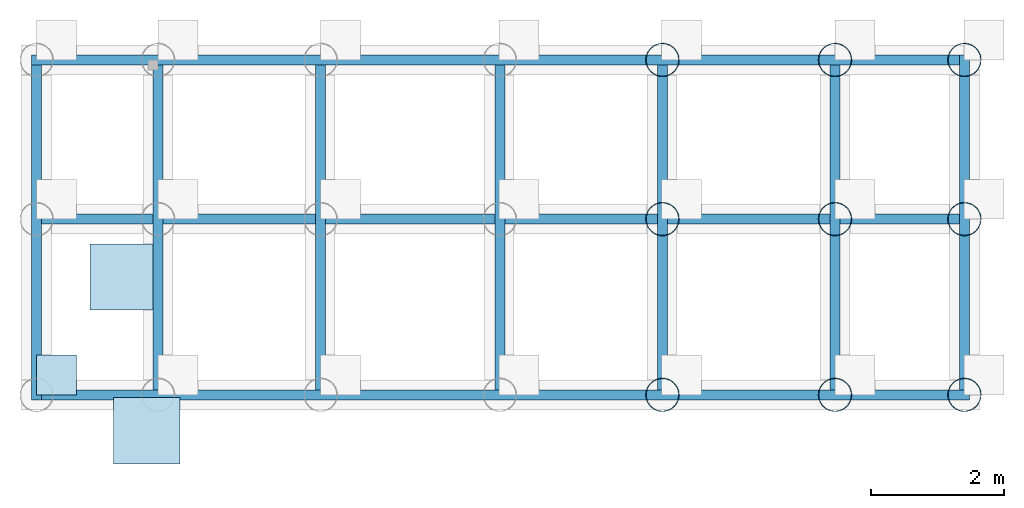
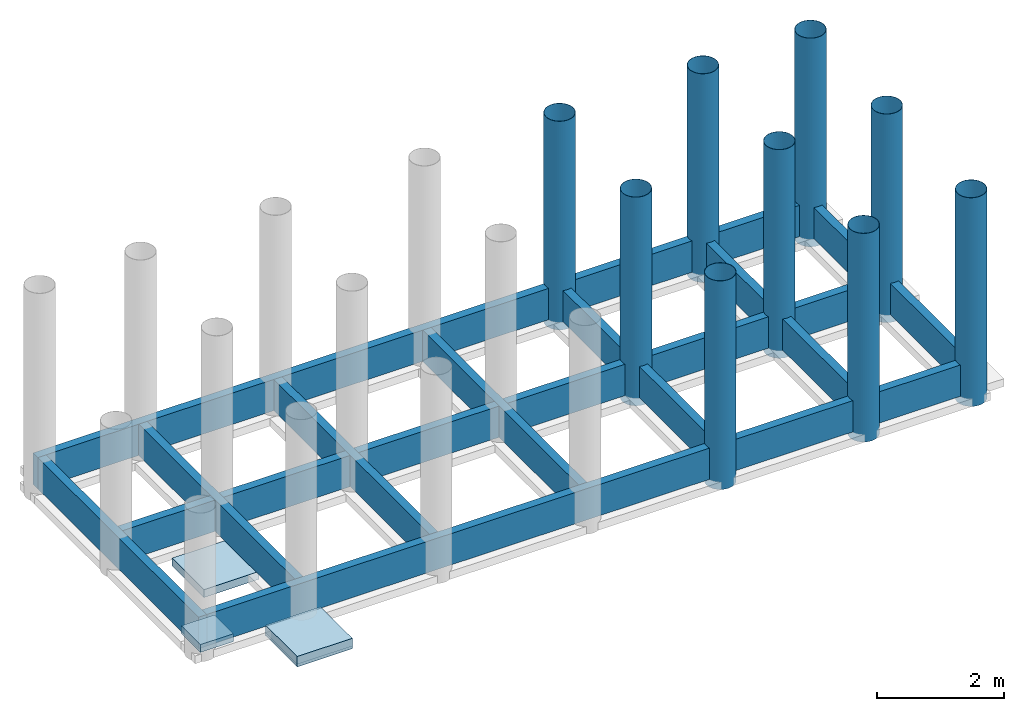
# One storey, part 2 of 2: 10 walls, 9 columns, 7 slabs.
"""IFC4 building model written with IfcOpenShell, lengths in millimetres."""

from ifc_helpers import new_model, entity, si_unit, converted_unit, frame, origin_with_axes, origin_2d_with_axis, place, context, subcontext, project, spatial, line, indexed_curve, rectangle, hollow_circle, outline, extrude, material, layer, layer_set, layer_usage, material_profile, profile_set, profile_usage, type_object, element, save


model = new_model("IFC4")

# Units and contexts
model_context = context("Model", 3, precision=1e-05, world=origin_with_axes())
plan_context = context("Plan", 2, precision=1e-05, world=origin_2d_with_axis())
body_context = subcontext(model_context, "Body", "Model", "MODEL_VIEW")
ifc_project = project(units=[si_unit("AREAUNIT", "SQUARE_METRE"), si_unit("VOLUMEUNIT", "CUBIC_METRE"), si_unit("LENGTHUNIT", "METRE", prefix="MILLI"), converted_unit("PLANEANGLEUNIT", "degree", entity("IfcReal", 0.0174532925199433), si_unit("PLANEANGLEUNIT", "RADIAN"), dimensions=[0, 0, 0, 0, 0, 0, 0])], contexts=[model_context, plan_context])

# Site, building, storey
site_placement = place(None, frame((-860.053181648254, 6515.22541046143, 2.98023223876953e-05), z_axis=(0.0, 0.0, 1.0), x_axis=(7.54979012640431e-08, -0.999999999999997, 0.0)))
site = spatial("IfcSite", under=ifc_project, at=site_placement)
building_placement = place(site_placement, frame((0.0, 0.0, 0.0), z_axis=(0.0, 0.0, 1.0), x_axis=(1.0, -1.32348898008484e-23, 0.0)))
building = spatial("IfcBuilding", under=site, at=building_placement, Name="Building")
storey_placement = place(building_placement, frame((0.222206115722656, -1.67760250135984e-08, -750.000089406967), z_axis=(0.0, 0.0, 1.0), x_axis=(7.54979012640431e-08, 0.999999999999997, 0.0)))
storey = spatial("IfcBuildingStorey", under=building, at=storey_placement, Name="FOUNDATION")

# Columns
ifc_material_1 = material(Name="Mass Concrete", Category="Concrete")
ifc_material_profile = material_profile(ifc_material_1, rectangle(XDim=150.0, YDim=150.0), Name="Square Column", Category="Structure", Priority=1)
ifc_profile_set = profile_set([ifc_material_profile], Name="RC_COL_150x150")
ifc_profile_usage_1 = profile_usage(ifc_profile_set, cardinal=5)
column_type = type_object("IfcColumnType", Name="C1", PredefinedType="NOTDEFINED", material=ifc_profile_set)
column_1_placement = place(storey_placement, frame((9554.95464801788, -626.263618469242, -149.999976158142), z_axis=(0.0, 0.0, 1.0), x_axis=(1.0, 1.32348898008484e-23, 0.0)))
element("IfcColumn", 1, at=column_1_placement, inside=storey, type_object=column_type, material=ifc_profile_usage_1, Name="C1", context=body_context, shape_type="SweptSolid", body=[
    extrude(hollow_circle(Radius=250.0, WallThickness=5.0), origin_with_axes(), (0.0, 0.0, 1.0), 4000.0),
])
ifc_profile_usage_2 = profile_usage(ifc_profile_set, cardinal=5)
column_2_placement = place(storey_placement, frame((12155.0036668777, -626.263618469242, -149.999976158142), z_axis=(0.0, 0.0, 1.0), x_axis=(1.0, 1.32348898008484e-23, 0.0)))
element("IfcColumn", 2, at=column_2_placement, inside=storey, type_object=column_type, material=ifc_profile_usage_2, Name="C1", context=body_context, shape_type="SweptSolid", body=[
    extrude(hollow_circle(Radius=250.0, WallThickness=5.0), origin_with_axes(), (0.0, 0.0, 1.0), 4000.0),
])
ifc_profile_usage_3 = profile_usage(ifc_profile_set, cardinal=5)
column_3_placement = place(storey_placement, frame((14105.0034761429, -626.263618469242, -149.999976158142), z_axis=(0.0, 0.0, 1.0), x_axis=(1.0, 1.32348898008484e-23, 0.0)))
element("IfcColumn", 3, at=column_3_placement, inside=storey, type_object=column_type, material=ifc_profile_usage_3, Name="C1", context=body_context, shape_type="SweptSolid", body=[
    extrude(hollow_circle(Radius=250.0, WallThickness=5.0), origin_with_axes(), (0.0, 0.0, 1.0), 4000.0),
])
ifc_profile_usage_4 = profile_usage(ifc_profile_set, cardinal=5)
column_4_placement = place(storey_placement, frame((14105.0034761429, -3024.68276023865, -149.999976158142), z_axis=(0.0, 0.0, 1.0), x_axis=(1.0, 1.32348898008484e-23, 0.0)))
element("IfcColumn", 4, at=column_4_placement, inside=storey, type_object=column_type, material=ifc_profile_usage_4, Name="C1", context=body_context, shape_type="SweptSolid", body=[
    extrude(hollow_circle(Radius=250.0, WallThickness=5.0), origin_with_axes(), (0.0, 0.0, 1.0), 4000.0),
])
ifc_profile_usage_5 = profile_usage(ifc_profile_set, cardinal=5)
column_5_placement = place(storey_placement, frame((14105.0034761429, -5672.84035682678, -149.999976158142), z_axis=(0.0, 0.0, 1.0), x_axis=(1.0, 1.32348898008484e-23, 0.0)))
element("IfcColumn", 5, at=column_5_placement, inside=storey, type_object=column_type, material=ifc_profile_usage_5, Name="C1", context=body_context, shape_type="SweptSolid", body=[
    extrude(hollow_circle(Radius=250.0, WallThickness=5.0), origin_with_axes(), (0.0, 0.0, 1.0), 4000.0),
])
ifc_profile_usage_6 = profile_usage(ifc_profile_set, cardinal=5)
column_6_placement = place(storey_placement, frame((12155.0046205521, -5672.84035682678, -149.999976158142), z_axis=(0.0, 0.0, 1.0), x_axis=(1.0, 1.32348898008484e-23, 0.0)))
element("IfcColumn", 6, at=column_6_placement, inside=storey, type_object=column_type, material=ifc_profile_usage_6, Name="C1", context=body_context, shape_type="SweptSolid", body=[
    extrude(hollow_circle(Radius=250.0, WallThickness=5.0), origin_with_axes(), (0.0, 0.0, 1.0), 4000.0),
])
ifc_profile_usage_7 = profile_usage(ifc_profile_set, cardinal=5)
column_7_placement = place(storey_placement, frame((9555.04906177521, -5672.84035682678, -149.999976158142), z_axis=(0.0, 0.0, 1.0), x_axis=(1.0, 1.32348898008484e-23, 0.0)))
element("IfcColumn", 7, at=column_7_placement, inside=storey, type_object=column_type, material=ifc_profile_usage_7, Name="C1", context=body_context, shape_type="SweptSolid", body=[
    extrude(hollow_circle(Radius=250.0, WallThickness=5.0), origin_with_axes(), (0.0, 0.0, 1.0), 4000.0),
])
ifc_profile_usage_8 = profile_usage(ifc_profile_set, cardinal=5)
column_8_placement = place(storey_placement, frame((9555.00137805939, -3024.67823028565, -149.999976158142), z_axis=(0.0, 0.0, 1.0), x_axis=(1.0, 1.32348898008484e-23, 0.0)))
element("IfcColumn", 8, at=column_8_placement, inside=storey, type_object=column_type, material=ifc_profile_usage_8, Name="C1", context=body_context, shape_type="SweptSolid", body=[
    extrude(hollow_circle(Radius=250.0, WallThickness=5.0), origin_with_axes(), (0.0, 0.0, 1.0), 4000.0),
])
ifc_profile_usage_9 = profile_usage(ifc_profile_set, cardinal=5)
column_9_placement = place(storey_placement, frame((12155.0036668777, -3024.67823028565, -149.999976158142), z_axis=(0.0, 0.0, 1.0), x_axis=(1.0, 1.32348898008484e-23, 0.0)))
element("IfcColumn", 9, at=column_9_placement, inside=storey, type_object=column_type, material=ifc_profile_usage_9, Name="C1", context=body_context, shape_type="SweptSolid", body=[
    extrude(hollow_circle(Radius=250.0, WallThickness=5.0), origin_with_axes(), (0.0, 0.0, 1.0), 4000.0),
])

# Slabs
ifc_layer_1 = layer(ifc_material_1, 150.0, Name="Foundation Footing Layer", Category="Substrate", Priority=1)
ifc_layer_set_1 = layer_set([ifc_layer_1])
ifc_layer_usage_1 = layer_usage(ifc_layer_set_1, "AXIS3", "POSITIVE", 0.0)
slab_type_1 = type_object("IfcSlabType", Name="FLR150", PredefinedType="NOTDEFINED", material=ifc_layer_set_1)
slab_1_placement = place(storey_placement, frame((929.933577775955, -4396.21543884278, -149.999976158142), z_axis=(0.0, 0.0, 1.0), x_axis=(1.0, 1.32348898008484e-23, 0.0)))
element("IfcSlab", 10, at=slab_1_placement, inside=storey, type_object=slab_type_1, material=ifc_layer_usage_1, Name="FLR150", context=body_context, shape_type="SweptSolid", body=[
    extrude(outline(indexed_curve([(0.0, 0.0), (1000.0, 0.0), (1000.0, 1000.0), (0.0, 1000.0), (0.0, 0.0)])), None, (0.0, 0.0, 1.0), 150.0),
])
ifc_layer_usage_2 = layer_usage(ifc_layer_set_1, "AXIS3", "POSITIVE", 0.0)
slab_2_placement = place(storey_placement, frame((1281.97777271271, -6713.08445930481, -149.999976158142), z_axis=(0.0, 0.0, 1.0), x_axis=(1.0, 1.32348898008484e-23, 0.0)))
element("IfcSlab", 11, at=slab_2_placement, inside=storey, type_object=slab_type_1, material=ifc_layer_usage_2, Name="FLR150", context=body_context, shape_type="SweptSolid", body=[
    extrude(outline(indexed_curve([(0.0, 0.0), (1000.0, 0.0), (1000.0, 1000.0), (0.0, 1000.0), (0.0, 0.0)])), None, (0.0, 0.0, 1.0), 150.0),
])
ifc_layer_2 = layer(ifc_material_1, 150.0, Name="Concrete Footing Layer", Category="Structure", Priority=1)
ifc_material_2 = material(Name="Light Concrete", Category="Concrete")
ifc_layer_3 = layer(ifc_material_2, 50.0, Name="Blinding Layer", Category="Substrate", Priority=2)
ifc_layer_set_2 = layer_set([ifc_layer_2, ifc_layer_3], Name="FTG_COL_2LYR")
ifc_layer_usage_3 = layer_usage(ifc_layer_set_2, "AXIS3", "POSITIVE", 0.0)
slab_type_2 = type_object("IfcSlabType", Name="FLR_150", PredefinedType="NOTDEFINED", material=ifc_layer_set_2)
slab_3_placement = place(storey_placement, frame((1281.97777271271, -6713.08445930481, -199.999988079071), z_axis=(0.0, 0.0, 1.0), x_axis=(1.0, 1.32348898008484e-23, 0.0)))
element("IfcSlab", 12, at=slab_3_placement, inside=storey, type_object=slab_type_2, material=ifc_layer_usage_3, Name="FLR_150", context=body_context, shape_type="SweptSolid", body=[
    extrude(outline(indexed_curve([(0.0, 0.0), (1000.0, 0.0), (1000.0, 1000.0), (0.0, 1000.0), (0.0, 0.0)])), None, (0.0, 0.0, 1.0), 200.0),
])
ifc_layer_usage_4 = layer_usage(ifc_layer_set_2, "AXIS3", "POSITIVE", 0.0)
slab_4_placement = place(storey_placement, frame((1281.97777271271, -6713.08445930481, -199.999988079071), z_axis=(0.0, 0.0, 1.0), x_axis=(1.0, 1.32348898008484e-23, 0.0)))
element("IfcSlab", 13, at=slab_4_placement, inside=storey, type_object=slab_type_2, material=ifc_layer_usage_4, Name="FLR_150", context=body_context, shape_type="SweptSolid", body=[
    extrude(outline(indexed_curve([(0.0, 0.0), (1000.0, 0.0), (1000.0, 1000.0), (0.0, 1000.0), (0.0, 0.0)])), None, (0.0, 0.0, 1.0), 200.0),
])
ifc_layer_4 = layer(ifc_material_1, 150.0, Name="Column Footing Layer", Category="Structure", Priority=1)
ifc_layer_set_3 = layer_set([ifc_layer_4], Name="FTG_COL_1LYR")
ifc_layer_usage_5 = layer_usage(ifc_layer_set_3, "AXIS3", "POSITIVE", 0.0)
slab_type_3 = type_object("IfcSlabType", Name="FLR_150", PredefinedType="NOTDEFINED", material=ifc_layer_set_3)
slab_5_placement = place(storey_placement, frame((124.994397163391, -5674.44968223572, -147.661149501801), z_axis=(0.0, 0.0, 1.0), x_axis=(1.0, 1.32348898008484e-23, 0.0)))
element("IfcSlab", 14, at=slab_5_placement, inside=storey, type_object=slab_type_3, material=ifc_layer_usage_5, Name="FLR250", context=body_context, shape_type="SweptSolid", body=[
    extrude(outline(indexed_curve([(0.0, 0.0), (600.000023841858, 0.0), (600.000023841858, 600.000023841858), (0.0, 600.000023841858)], segments=[line(3, 2), line(2, 1), line(1, 4), line(4, 3)], self_intersect=False)), None, (0.0, 0.0, 1.0), 150.0),
])
ifc_layer_usage_6 = layer_usage(ifc_layer_set_3, "AXIS3", "POSITIVE", 0.0)
slab_6_placement = place(storey_placement, frame((124.994397163391, -5674.44968223572, -147.661149501801), z_axis=(0.0, 0.0, 1.0), x_axis=(1.0, 1.32348898008484e-23, 0.0)))
element("IfcSlab", 15, at=slab_6_placement, inside=storey, type_object=slab_type_3, material=ifc_layer_usage_6, Name="FLR250", context=body_context, shape_type="SweptSolid", body=[
    extrude(outline(indexed_curve([(0.0, 0.0), (600.000023841858, 0.0), (600.000023841858, 600.000023841858), (0.0, 600.000023841858)], segments=[line(3, 2), line(2, 1), line(1, 4), line(4, 3)], self_intersect=False)), None, (0.0, 0.0, 1.0), 150.0),
])
ifc_layer_usage_7 = layer_usage(ifc_layer_set_3, "AXIS3", "POSITIVE", 0.0)
slab_7_placement = place(storey_placement, frame((124.994397163391, -5674.44968223572, -147.661149501801), z_axis=(0.0, 0.0, 1.0), x_axis=(1.0, 1.32348898008484e-23, 0.0)))
element("IfcSlab", 16, at=slab_7_placement, inside=storey, type_object=slab_type_3, material=ifc_layer_usage_7, Name="FLR250", context=body_context, shape_type="SweptSolid", body=[
    extrude(outline(indexed_curve([(0.0, 0.0), (600.000023841858, 0.0), (600.000023841858, 600.000023841858), (0.0, 600.000023841858)], segments=[line(3, 2), line(2, 1), line(1, 4), line(4, 3)], self_intersect=False)), None, (0.0, 0.0, 1.0), 150.0),
])

# Walls
ifc_material_3 = material(Category="Blockwork")
ifc_layer_5 = layer(ifc_material_3, 150.0, Name="Blockwork core", Category="Structure", Priority=1)
ifc_layer_set_4 = layer_set([ifc_layer_5])
ifc_layer_usage_8 = layer_usage(ifc_layer_set_4, "AXIS2", "POSITIVE", 0.0)
wall_type = type_object("IfcWallType", Name="FND150_CRX", PredefinedType="SOLIDWALL", material=ifc_layer_set_4)
wall_1_placement = place(storey_placement, frame((49.9976277351375, -699.673175811771, 5.96046446643683e-05), z_axis=(0.0, 0.0, 1.0), x_axis=(-6.39757843145941e-07, -0.999999999999795, 0.0)))
element("IfcWall", 17, at=wall_1_placement, inside=storey, type_object=wall_type, material=ifc_layer_usage_8, Name="WAL200", context=body_context, shape_type="SweptSolid", body=[
    extrude(outline(indexed_curve([(0.0, 0.0), (0.0, 150.0), (5049.79571694215, 150.0), (5049.79571694215, 0.0), (0.0, 0.0)], self_intersect=False)), origin_with_axes(), (0.0, 0.0, 1.0), 600.000023841858),
])
ifc_layer_usage_9 = layer_usage(ifc_layer_set_4, "AXIS2", "POSITIVE", 0.0)
wall_2_placement = place(storey_placement, frame((14030.0046205521, -549.669265747074, 5.96046446643683e-05), z_axis=(0.0, 0.0, 1.0), x_axis=(-0.99999999999939, 1.10467010472281e-06, 0.0)))
element("IfcWall", 18, at=wall_2_placement, inside=storey, type_object=wall_type, material=ifc_layer_usage_9, Name="WAL200", context=body_context, shape_type="SweptSolid", body=[
    extrude(outline(indexed_curve([(0.0, 0.0), (0.0, 150.0), (13980.0070648914, 150.0), (13980.0070648914, 0.0), (0.0, 0.0)], self_intersect=False)), origin_with_axes(), (0.0, 0.0, 1.0), 600.000023841858),
])
ifc_layer_usage_10 = layer_usage(ifc_layer_set_4, "AXIS2", "POSITIVE", 0.0)
wall_3_placement = place(storey_placement, frame((1880.0003528595, -699.673175811771, 5.96046446643683e-05), z_axis=(0.0, 0.0, 1.0), x_axis=(3.13916473260163e-07, -0.99999999999995, 0.0)))
element("IfcWall", 19, at=wall_3_placement, inside=storey, type_object=wall_type, material=ifc_layer_usage_10, Name="WAL200", context=body_context, shape_type="SweptSolid", body=[
    extrude(outline(indexed_curve([(0.0, 0.0), (0.0, 150.0), (4899.78417680314, 150.0), (4899.78417680314, 0.0), (0.0, 0.0)], self_intersect=False)), origin_with_axes(), (0.0, 0.0, 1.0), 600.000023841858),
])
ifc_layer_usage_11 = layer_usage(ifc_layer_set_4, "AXIS2", "POSITIVE", 0.0)
wall_4_placement = place(storey_placement, frame((7180.00042438507, -5599.45386648178, 5.96046446643683e-05), z_axis=(0.0, 0.0, 1.0), x_axis=(6.71544341912371e-07, 0.999999999999774, 0.0)))
element("IfcWall", 20, at=wall_4_placement, inside=storey, type_object=wall_type, material=ifc_layer_usage_11, Name="WAL200", context=body_context, shape_type="SweptSolid", body=[
    extrude(outline(indexed_curve([(0.0, 0.0), (0.0, 150.0), (4899.77600208587, 150.0), (4899.77600208587, 0.0), (0.0, 0.0)], self_intersect=False)), origin_with_axes(), (0.0, 0.0, 1.0), 600.000023841858),
])
ifc_layer_usage_12 = layer_usage(ifc_layer_set_4, "AXIS2", "POSITIVE", 0.0)
wall_5_placement = place(storey_placement, frame((199.997544288635, -3099.67756271363, 5.96046446643683e-05), z_axis=(0.0, 0.0, 1.0), x_axis=(0.999999999999936, -3.57627868652321e-07, 0.0)))
element("IfcWall", 21, at=wall_5_placement, inside=storey, type_object=wall_type, material=ifc_layer_usage_12, Name="SLD150", PredefinedType="SOLIDWALL", context=body_context, shape_type="SweptSolid", body=[
    extrude(outline(indexed_curve([(0.0, 0.0), (0.0, 150.0), (13830.0057204458, 150.0), (13830.0057204458, 0.0), (0.0, 0.0)], self_intersect=False)), origin_with_axes(), (0.0, 0.0, 1.0), 600.000023841858),
])
ifc_layer_usage_13 = layer_usage(ifc_layer_set_4, "AXIS2", "POSITIVE", 0.0)
wall_6_placement = place(storey_placement, frame((12080.0029039383, -699.669361114505, 5.96046446643683e-05), z_axis=(0.0, 0.0, 1.0), x_axis=(3.13916473260163e-07, -0.99999999999995, 0.0)))
element("IfcWall", 22, at=wall_6_placement, inside=storey, type_object=wall_type, material=ifc_layer_usage_13, Name="WAL200", context=body_context, shape_type="SweptSolid", body=[
    extrude(outline(indexed_curve([(0.0, 0.0), (0.0, 150.0), (4899.78417680327, 150.0), (4899.78417680327, 0.0), (0.0, 0.0)], self_intersect=False)), origin_with_axes(), (0.0, 0.0, 1.0), 600.000023841858),
])
ifc_layer_usage_14 = layer_usage(ifc_layer_set_4, "AXIS2", "POSITIVE", 0.0)
wall_7_placement = place(storey_placement, frame((14180.0023317337, -5599.45702552796, -1.11022302462516e-13), z_axis=(0.0, 0.0, 1.0), x_axis=(3.13916473260163e-07, 0.99999999999995, 0.0)))
element("IfcWall", 23, at=wall_7_placement, inside=storey, type_object=wall_type, material=ifc_layer_usage_14, Name="WAL200", context=body_context, shape_type="SweptSolid", body=[
    extrude(outline(indexed_curve([(0.0, 0.0), (0.0, 150.0), (5049.78041974117, 150.0), (5049.78041974117, 0.0), (0.0, 0.0)], self_intersect=False)), origin_with_axes(), (0.0, 0.0, 1.0), 600.000023841858),
])
ifc_layer_usage_15 = layer_usage(ifc_layer_set_4, "AXIS2", "POSITIVE", 0.0)
wall_8_placement = place(storey_placement, frame((199.994385242462, -5749.44967031479, -1.11022302462516e-13), z_axis=(0.0, 0.0, 1.0), x_axis=(1.0, 1.32348898008484e-23, 0.0)))
element("IfcWall", 24, at=wall_8_placement, inside=storey, type_object=wall_type, material=ifc_layer_usage_15, Name="WAL200", context=body_context, shape_type="SweptSolid", body=[
    extrude(outline(indexed_curve([(0.0, 0.0), (0.0, 150.0), (13980.0092478273, 150.0), (13980.0092478273, 0.0), (0.0, 0.0)], self_intersect=False)), origin_with_axes(), (0.0, 0.0, 1.0), 600.000023841858),
])
ifc_layer_usage_16 = layer_usage(ifc_layer_set_4, "AXIS2", "POSITIVE", 0.0)
wall_9_placement = place(storey_placement, frame((4330.0005197525, -699.672698974613, 5.96046446643683e-05), z_axis=(0.0, 0.0, 1.0), x_axis=(3.13916473260163e-07, -0.99999999999995, 0.0)))
element("IfcWall", 25, at=wall_9_placement, inside=storey, type_object=wall_type, material=ifc_layer_usage_16, Name="WAL200", context=body_context, shape_type="SweptSolid", body=[
    extrude(outline(indexed_curve([(0.0, 0.0), (0.0, 150.0), (4899.78320362309, 150.0), (4899.78320362309, 0.0), (0.0, 0.0)], self_intersect=False)), origin_with_axes(), (0.0, 0.0, 1.0), 600.000023841858),
])
ifc_layer_usage_17 = layer_usage(ifc_layer_set_4, "AXIS2", "POSITIVE", 0.0)
wall_10_placement = place(storey_placement, frame((9630.00023365021, -5599.45696592331, 5.96046446643683e-05), z_axis=(0.0, 0.0, 1.0), x_axis=(6.71544341912371e-07, 0.999999999999774, 0.0)))
element("IfcWall", 26, at=wall_10_placement, inside=storey, type_object=wall_type, material=ifc_layer_usage_17, Name="WAL200", context=body_context, shape_type="SweptSolid", body=[
    extrude(outline(indexed_curve([(0.0, 0.0), (0.0, 150.0), (4899.77463963122, 150.0), (4899.77463963122, 0.0), (0.0, 0.0)], self_intersect=False)), origin_with_axes(), (0.0, 0.0, 1.0), 600.000023841858),
])

save(model, "model.ifc")
